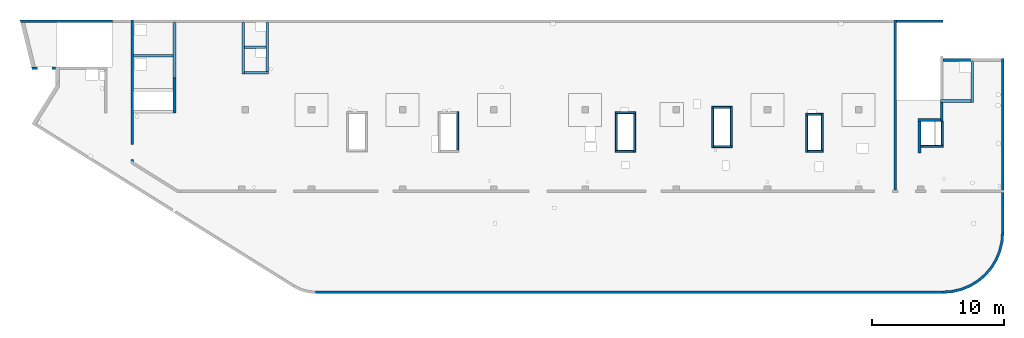
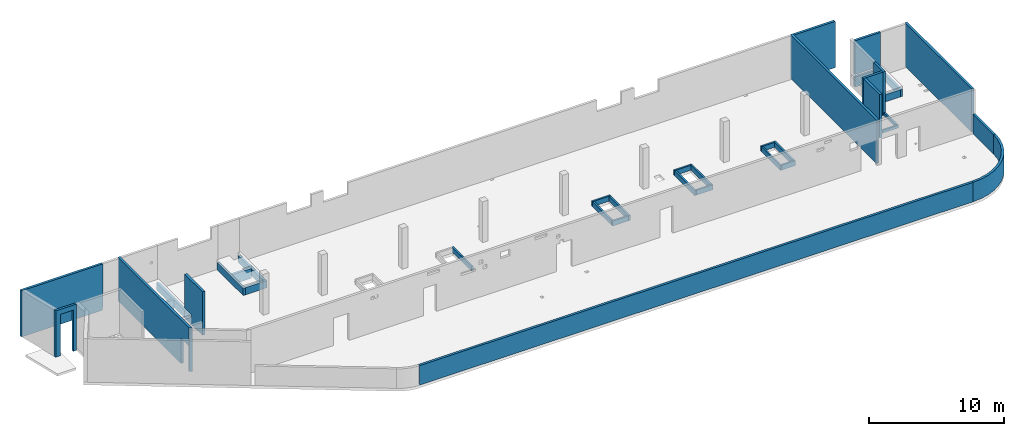
# One storey, part 3 of 6: 37 walls, 3 openings.
"""IFC4 building model written with IfcOpenShell, lengths in millimetres."""

import ifcopenshell
import ifcopenshell.guid

model = None  # the IFC model being written
_history = None  # IfcOwnerHistory: only IFC2X3 demands one
_inside = {}  # id of a spatial element -> (the spatial element, [elements in it])
_under = {}  # id of a project, library or spatial element -> (it, [spatial elements below it])
_declared = {}  # id of a project -> (the project, [libraries it declares])
_typed = {}  # id of a type object -> (the type object, [elements of that type])
_made_of = {}  # id of a material, layer set ... -> (it, [elements and type objects made of it])


def new_model(schema):
    """Start an empty IFC model of exactly this schema.

    Asked for "IFC4X3", IfcOpenShell would pick the latest addendum, in which some entities
    have other attributes; the version numbers below select the first issue.
    IFC2X3 requires an IfcOwnerHistory on every rooted entity: one is made here for all.
    """
    global model, _history
    if schema == "IFC4X3":
        model = ifcopenshell.file(schema_version=(4, 3, 0, 0))
    else:
        model = ifcopenshell.file(schema=schema)
    _inside.clear()
    _under.clear()
    _declared.clear()
    _typed.clear()
    _made_of.clear()
    _history = None
    if model.schema == "IFC2X3":
        org = make("IfcOrganization", Name="unknown")
        user = make(
            "IfcPersonAndOrganization",
            ThePerson=make("IfcPerson", FamilyName="unknown"),
            TheOrganization=org,
        )
        app = make(
            "IfcApplication",
            ApplicationDeveloper=org,
            Version="unknown",
            ApplicationFullName="unknown",
            ApplicationIdentifier="unknown",
        )
        _history = make(
            "IfcOwnerHistory",
            OwningUser=user,
            OwningApplication=app,
            ChangeAction="ADDED",
            CreationDate=0,
        )
    return model


def make(cls, **values):
    """One entity of the class cls with the attributes given. An attribute that is None is left unset."""
    return model.create_entity(
        cls, **{name: value for name, value in values.items() if value is not None}
    )


def entity(cls, *values):
    """Any entity or typed value of the class cls, its attributes in the order of the schema. None: left unset."""
    e = model.create_entity(cls)
    for i, value in enumerate(values):
        if value is not None:
            e[i] = value
    return e


def rooted(cls, **values):
    """An entity with a GlobalId (a new one), such as an element, a storey or a relation."""
    return make(cls, GlobalId=ifcopenshell.guid.new(), OwnerHistory=_history, **values)


def si_unit(unit_type, name, prefix=None):
    """IfcSIUnit, for example si_unit("LENGTHUNIT", "METRE", prefix="MILLI")."""
    return make("IfcSIUnit", UnitType=unit_type, Prefix=prefix, Name=name)


def converted_unit(unit_type, name, factor, base, dimensions=None, offset=None):
    """IfcConversionBasedUnit, such as the inch: factor (a typed value) times the base unit."""
    return make(
        "IfcConversionBasedUnit"
        if offset is None
        else "IfcConversionBasedUnitWithOffset",
        ConversionOffset=offset,
        Dimensions=None
        if dimensions is None
        else entity("IfcDimensionalExponents", *dimensions),
        UnitType=unit_type,
        Name=name,
        ConversionFactor=make(
            "IfcMeasureWithUnit", ValueComponent=factor, UnitComponent=base
        ),
    )


def derived_unit(unit_type, elements):
    """IfcDerivedUnit: a product of units, each with its exponent."""
    return make(
        "IfcDerivedUnit",
        Elements=[
            make("IfcDerivedUnitElement", Unit=unit, Exponent=power)
            for unit, power in elements
        ],
        UnitType=unit_type,
    )


def assignment(units):
    """IfcUnitAssignment: the units of a project."""
    return None if units is None else make("IfcUnitAssignment", Units=units)


def point(xyz):
    """IfcCartesianPoint."""
    return None if xyz is None else make("IfcCartesianPoint", Coordinates=xyz)


def direction(xyz):
    """IfcDirection."""
    return None if xyz is None else make("IfcDirection", DirectionRatios=xyz)


def frame(location, z_axis=None, x_axis=None):
    """IfcAxis2Placement3D, a coordinate frame: its origin and axes. An axis left out is left unset."""
    return make(
        "IfcAxis2Placement3D",
        Location=point(location),
        Axis=direction(z_axis),
        RefDirection=direction(x_axis),
    )


def origin():
    """The frame at (0, 0, 0) with its axes left unset."""
    return frame((0.0, 0.0, 0.0))


def place(relative_to, where):
    """IfcLocalPlacement: puts the frame where relative to a parent placement (None: the world)."""
    return make(
        "IfcLocalPlacement", PlacementRelTo=relative_to, RelativePlacement=where
    )


def context(
    kind, dimensions, precision=None, world=None, true_north=None, identifier=None
):
    """IfcGeometricRepresentationContext, for example the 3D "Model" context."""
    return make(
        "IfcGeometricRepresentationContext",
        ContextIdentifier=identifier,
        ContextType=kind,
        CoordinateSpaceDimension=dimensions,
        Precision=precision,
        WorldCoordinateSystem=world,
        TrueNorth=true_north,
    )


def subcontext(parent, identifier, kind, view, scale=None):
    """IfcGeometricRepresentationSubContext, for example "Body" below "Model"."""
    return make(
        "IfcGeometricRepresentationSubContext",
        ContextIdentifier=identifier,
        ContextType=kind,
        ParentContext=parent,
        TargetScale=scale,
        TargetView=view,
    )


def project(units=None, contexts=None):
    """IfcProject with its units and contexts."""
    return rooted(
        "IfcProject",
        Name="project",
        RepresentationContexts=contexts,
        UnitsInContext=assignment(units),
    )


def spatial(cls, under=None, at=None, **own):
    """A site, building, storey or space (cls), placed at a placement, below another one or the project."""
    s = rooted(cls, ObjectPlacement=at, **own)
    if under is not None:
        _under.setdefault(under.id(), (under, []))[1].append(s)
    return s


def point_list(points):
    """IfcCartesianPointList2D or 3D."""
    cls = (
        "IfcCartesianPointList2D" if len(points[0]) == 2 else "IfcCartesianPointList3D"
    )
    return make(cls, CoordList=points)


def indexed_curve(points, segments=None, self_intersect=None):
    """IfcIndexedPolyCurve: lines and arcs through numbered points (the first is 1)."""
    return make(
        "IfcIndexedPolyCurve",
        Points=point_list(points),
        Segments=segments,
        SelfIntersect=self_intersect,
    )


def outline(outer, holes=None, kind="AREA"):
    """IfcArbitraryClosedProfileDef: a profile drawn as a closed curve; with holes, ...WithVoids."""
    if holes is None:
        return make("IfcArbitraryClosedProfileDef", ProfileType=kind, OuterCurve=outer)
    return make(
        "IfcArbitraryProfileDefWithVoids",
        ProfileType=kind,
        OuterCurve=outer,
        InnerCurves=holes,
    )


def extrude(swept, where, along, depth):
    """IfcExtrudedAreaSolid: the profile swept, set in the frame where, extruded along a direction by depth."""
    return make(
        "IfcExtrudedAreaSolid",
        SweptArea=swept,
        Position=where,
        ExtrudedDirection=direction(along),
        Depth=depth,
    )


def polygons(points, faces, closed=None, point_numbers=None):
    """IfcPolygonalFaceSet: a face is its outer loop, then its inner loops; points numbered from 1."""
    made = []
    for loops in faces:
        if len(loops) == 1:
            made.append(make("IfcIndexedPolygonalFace", CoordIndex=loops[0]))
        else:
            made.append(
                make(
                    "IfcIndexedPolygonalFaceWithVoids",
                    CoordIndex=loops[0],
                    InnerCoordIndices=loops[1:],
                )
            )
    return make(
        "IfcPolygonalFaceSet",
        Coordinates=point_list(points),
        Closed=closed,
        Faces=made,
        PnIndex=point_numbers,
    )


def shape(context_of_items, identifier, shape_type, items):
    """IfcShapeRepresentation: the items that make up one representation, for example the "Body"."""
    return make(
        "IfcShapeRepresentation",
        ContextOfItems=context_of_items,
        RepresentationIdentifier=identifier,
        RepresentationType=shape_type,
        Items=items,
    )


def material(Name=None, Category=None):
    """IfcMaterial."""
    return make("IfcMaterial", Name=Name, Category=Category)


def made_of(thing, what):
    """Note that an element or type object is made of a material, layer set ...; save() writes the relation."""
    if what is not None:
        _made_of.setdefault(what.id(), (what, []))[1].append(thing)
    return thing


def type_object(cls, material=None, **own):
    """A type object (cls), such as IfcWallType, which elements share."""
    return made_of(rooted(cls, **own), material)


def element(
    cls,
    number,
    at=None,
    inside=None,
    cuts=None,
    type_object=None,
    material=None,
    context=None,
    identifier="Body",
    shape_type=None,
    held_by="IfcProductDefinitionShape",
    body=None,
    shapes=None,
    **own,
):
    """One element of the class cls, such as IfcWall. Its Tag is "e" and its number.

    at: its placement. inside: the storey or other place that contains it. cuts: it is an
    opening in that element (IfcRelVoidsElement). A single representation is given by context,
    identifier, shape_type and body (its items); several are given by shapes. held_by: the class
    of the entity that holds the representations. save() writes the other relations.
    """
    e = rooted(cls, Tag="e%d" % number, ObjectPlacement=at, **own)
    if body is not None:
        shapes = [shape(context, identifier, shape_type, body)]
    if shapes is not None:
        e.Representation = make(held_by, Representations=shapes)
    if inside is not None:
        _inside.setdefault(inside.id(), (inside, []))[1].append(e)
    if cuts is not None:
        rooted(
            "IfcRelVoidsElement", RelatingBuildingElement=cuts, RelatedOpeningElement=e
        )
    if type_object is not None:
        _typed.setdefault(type_object.id(), (type_object, []))[1].append(e)
    return made_of(e, material)


def aggregate(whole, parts):
    """IfcRelAggregates: a whole, such as a stair, and the parts it consists of."""
    return rooted("IfcRelAggregates", RelatingObject=whole, RelatedObjects=parts)


def save(model, path):
    """Write the relations noted so far, then the file.

    IfcRelAggregates (storeys below a building ...), IfcRelContainedInSpatialStructure (elements
    in a storey), IfcRelDefinesByType, IfcRelAssociatesMaterial and IfcRelDeclares: one each for
    every whole, place, type object, material and project.
    """
    for whole, parts in _under.values():
        aggregate(whole, parts)
    for where, things in _inside.values():
        rooted(
            "IfcRelContainedInSpatialStructure",
            RelatedElements=things,
            RelatingStructure=where,
        )
    for kind, things in _typed.values():
        rooted("IfcRelDefinesByType", RelatedObjects=things, RelatingType=kind)
    for what, things in _made_of.values():
        rooted("IfcRelAssociatesMaterial", RelatedObjects=things, RelatingMaterial=what)
    for by, libraries in _declared.values():
        rooted("IfcRelDeclares", RelatingContext=by, RelatedDefinitions=libraries)
    model.write(path)


model = new_model("IFC4")

# Units and contexts
model_context = context("Model", 3, precision=0.01, world=origin(), true_north=direction((6.12303176911189e-17, 1.0)))
plan_context = context("Plan", 3, precision=0.01, world=origin(), true_north=direction((6.12303176911189e-17, 1.0)))
body_context = subcontext(model_context, "Body", "Model", "MODEL_VIEW")
ifc_project = project(units=[si_unit("LENGTHUNIT", "METRE", prefix="MILLI"), si_unit("AREAUNIT", "SQUARE_METRE"), si_unit("VOLUMEUNIT", "CUBIC_METRE"), converted_unit("PLANEANGLEUNIT", "DEGREE", entity("IfcRatioMeasure", 0.0174532925199433), si_unit("PLANEANGLEUNIT", "RADIAN"), dimensions=[0, 0, 0, 0, 0, 0, 0]), si_unit("MASSUNIT", "GRAM", prefix="KILO"), derived_unit("MASSDENSITYUNIT", [(si_unit("MASSUNIT", "GRAM", prefix="KILO"), 1), (si_unit("LENGTHUNIT", "METRE"), -3)]), derived_unit("MOMENTOFINERTIAUNIT", [(si_unit("LENGTHUNIT", "METRE"), 4)]), si_unit("TIMEUNIT", "SECOND"), si_unit("FREQUENCYUNIT", "HERTZ"), si_unit("THERMODYNAMICTEMPERATUREUNIT", "DEGREE_CELSIUS"), derived_unit("THERMALTRANSMITTANCEUNIT", [(si_unit("MASSUNIT", "GRAM", prefix="KILO"), 1), (si_unit("THERMODYNAMICTEMPERATUREUNIT", "KELVIN"), -1), (si_unit("TIMEUNIT", "SECOND"), -3)]), derived_unit("VOLUMETRICFLOWRATEUNIT", [(si_unit("LENGTHUNIT", "METRE"), 3), (si_unit("TIMEUNIT", "SECOND"), -1)]), derived_unit("MASSFLOWRATEUNIT", [(si_unit("MASSUNIT", "GRAM", prefix="KILO"), 1), (si_unit("TIMEUNIT", "SECOND"), -1)]), derived_unit("ROTATIONALFREQUENCYUNIT", [(si_unit("TIMEUNIT", "SECOND"), -1)]), si_unit("ELECTRICCURRENTUNIT", "AMPERE"), si_unit("ELECTRICVOLTAGEUNIT", "VOLT"), si_unit("POWERUNIT", "WATT"), si_unit("FORCEUNIT", "NEWTON", prefix="KILO"), si_unit("ILLUMINANCEUNIT", "LUX"), si_unit("LUMINOUSFLUXUNIT", "LUMEN"), si_unit("LUMINOUSINTENSITYUNIT", "CANDELA"), derived_unit("USERDEFINED", [(si_unit("MASSUNIT", "GRAM", prefix="KILO"), -1), (si_unit("LENGTHUNIT", "METRE"), -2), (si_unit("TIMEUNIT", "SECOND"), 3), (si_unit("LUMINOUSFLUXUNIT", "LUMEN"), 1)]), derived_unit("LINEARVELOCITYUNIT", [(si_unit("LENGTHUNIT", "METRE"), 1), (si_unit("TIMEUNIT", "SECOND"), -1)]), si_unit("PRESSUREUNIT", "PASCAL"), derived_unit("USERDEFINED", [(si_unit("LENGTHUNIT", "METRE"), -2), (si_unit("MASSUNIT", "GRAM", prefix="KILO"), 1), (si_unit("TIMEUNIT", "SECOND"), -2)]), derived_unit("LINEARFORCEUNIT", [(si_unit("MASSUNIT", "GRAM", prefix="KILO"), 1), (si_unit("LENGTHUNIT", "METRE"), 1), (si_unit("TIMEUNIT", "SECOND"), -2), (si_unit("LENGTHUNIT", "METRE"), -1)]), derived_unit("PLANARFORCEUNIT", [(si_unit("MASSUNIT", "GRAM", prefix="KILO"), 1), (si_unit("LENGTHUNIT", "METRE"), 1), (si_unit("TIMEUNIT", "SECOND"), -2), (si_unit("LENGTHUNIT", "METRE"), -2)])], contexts=[model_context, plan_context])

# Site, building, storey
site_placement = place(None, origin())
site = spatial("IfcSite", under=ifc_project, at=site_placement, CompositionType="ELEMENT")
building_placement = place(site_placement, origin())
building = spatial("IfcBuilding", under=site, at=building_placement, CompositionType="ELEMENT")
storey_placement = place(building_placement, frame((0.0, 0.0, 28200.0)))
storey = spatial("IfcBuildingStorey", under=building, at=storey_placement, CompositionType="ELEMENT", Elevation=28200.0)

# Wall, opening
ifc_material = material()
wall_type_1 = type_object("IfcWallType", PredefinedType="STANDARD")
wall_1_placement = place(storey_placement, frame((1805.00026855469, 16859.9992263559, -400.0), z_axis=(0.0, 0.0, 1.0), x_axis=(-1.0, 0.0, 0.0)))
wall_1 = element("IfcWall", 1, at=wall_1_placement, inside=storey, type_object=wall_type_1, material=ifc_material, PredefinedType="NOTDEFINED", context=body_context, shape_type="Tessellation", body=[
    polygons([(1834.46650967482, -100.000000000001, 4200.0), (1525.68223251125, -100.000000000001, 4200.0), (2.33197173806285e-13, -100.000000000001, 4200.0), (2.33197173806285e-13, -100.000000000001, 249.999999999999), (2.33197173806285e-13, -100.000000000001, 0.0), (275.0, -100.000000000001, 0.0), (275.0, -100.000000000322, 3750.0), (1375.0, -100.000000000324, 3750.0), (1375.0, -100.000000000003, 0.0), (1525.68223251125, -100.000000000001, 0.0), (1834.46650967482, -100.000000000001, 0.0), (-6.38934712472434e-14, 100.000000000001, 4200.0), (1785.71439371649, 99.9999999999989, 4200.0), (1785.71439371649, 99.9999999999989, 0.0), (1375.0, 99.9999999999968, 0.0), (1375.0, 99.9999999999968, 3750.00000000001), (275.0, 100.000000000001, 3750.00000000001), (275.0, 100.000000000001, 0.0), (-6.38934712472434e-14, 100.000000000001, 0.0)], [[[1, 2, 3, 4, 5, 6, 7, 8, 9, 10, 11]], [[12, 13, 14, 15, 16, 17, 18, 19]], [[5, 19, 18, 6]], [[3, 2, 1, 13, 12]], [[5, 4, 3, 12, 19]], [[1, 11, 14, 13]], [[16, 8, 7, 17]], [[8, 16, 15, 9]], [[17, 7, 6, 18]], [[14, 11, 10, 9, 15]]], closed=True),
])
opening_1_placement = place(wall_1_placement, frame((1805.00026855469, 16859.9992263559, 400.0), z_axis=(0.0, 0.0, 1.0), x_axis=(-1.0, 0.0, 0.0)))
element("IfcOpeningElement", 2, at=opening_1_placement, cuts=wall_1, PredefinedType="OPENING", context=body_context, shape_type="SweptSolid", body=[
    extrude(outline(indexed_curve([(-550.0, -3149.99999999999), (550.0, -3149.99999999999), (550.0, 3149.99999999999), (-550.0, 3149.99999999999), (-550.0, -3149.99999999999)], self_intersect=False)), frame((980.000268554694, 16959.9992263569, 200.0), z_axis=(0.0, -1.0, 0.0), x_axis=(-1.0, 0.0, 0.0)), (0.0, 0.0, 1.0), 200.000000000962),
])

# Wall
wall_2_placement = place(storey_placement, frame((-892.378849434978, 20399.9998657227, -400.0)))
element("IfcWall", 3, at=wall_2_placement, inside=storey, type_object=wall_type_1, material=ifc_material, PredefinedType="NOTDEFINED", context=body_context, shape_type="Tessellation", body=[
    polygons([(6992.37911798968, -99.9999999999989, 4200.0), (357.536393121909, -99.9999999999989, 4200.0), (48.7521159583308, -100.000000000003, 4200.0), (48.7521159583318, -100.000000000003, 0.0), (357.536393121908, -99.9999999999989, 0.0), (6962.37911798968, -99.9999999999989, 0.0), (6962.37911798968, -99.9999999999989, 249.999999999999), (6992.37911798968, -99.9999999999989, 249.999999999999), (8.98797485695457e-13, 99.9999999999989, 4200.0), (0.379117989658529, 99.9999999999989, 4200.0), (6992.37911798968, 100.000000000003, 4200.0), (6992.37911798968, 100.000000000003, 249.999999999999), (6962.37911798968, 100.000000000008, 249.999999999999), (6962.37911798968, 100.000000000003, 0.0), (308.784277163562, 100.000000000003, 0.0), (-4.87112524406362e-14, 99.9999999999989, 0.0)], [[[1, 2, 3, 4, 5, 6, 7, 8]], [[9, 10, 11, 12, 13, 14, 15, 16]], [[4, 16, 15, 14, 6, 5]], [[11, 1, 8, 12]], [[3, 2, 1, 11, 10, 9]], [[4, 3, 9, 16]], [[7, 13, 12, 8]], [[13, 7, 6, 14]]], closed=True),
])

# Wall, opening
wall_3_placement = place(storey_placement, frame((7600.0002685547, 20499.9998657227, -150.0), z_axis=(0.0, 0.0, 1.0), x_axis=(0.0, -1.0, 0.0)))
wall_3 = element("IfcWall", 4, at=wall_3_placement, inside=storey, type_object=wall_type_1, material=ifc_material, PredefinedType="NOTDEFINED", context=body_context, shape_type="Tessellation", body=[
    polygons([(10624.9984109254, -99.9999999999999, 3950.0), (1979.99999999983, -100.0, 3950.0), (1019.99999999983, -99.9999999999994, 3950.0), (200.000000000037, -99.9999999999996, 3950.0), (0.0, -100.000000000001, 3950.0), (0.0, -100.000000000001, 0.0), (200.000000000037, -99.9999999999996, 0.0), (9420.00063936629, -99.9999999999996, 0.0), (9420.00063936629, -99.9999999999996, 2279.99999999804), (10550.0006393663, -99.999999999999, 2279.99999999804), (10550.0006393663, -100.0, 0.0), (10624.9984109254, -99.9999999999999, 0.0), (0.0, 100.0, 3950.0), (199.999999999998, 100.0, 3950.0), (10749.9698423134, 100.0, 3950.0), (10749.9698423134, 100.0, 0.0), (10550.0006393663, 100.0, 0.0), (10550.0006393663, 100.0, 2279.99999999804), (9420.0006393663, 100.0, 2279.99999999804), (9420.00063936629, 100.0, 0.0), (7050.00063936683, 100.0, 0.0), (6850.00063936683, 100.000000000001, 0.0), (6800.00000000003, 100.000000000001, 0.0), (5400.00000000003, 100.000000000001, 0.0), (5200.00000000003, 100.0, 0.0), (0.0, 100.0, 0.0)], [[[1, 2, 3, 4, 5, 6, 7, 8, 9, 10, 11, 12]], [[13, 14, 15, 16, 17, 18, 19, 20, 21, 22, 23, 24, 25, 26]], [[6, 26, 25, 24, 23, 22, 21, 20, 8, 7]], [[5, 4, 3, 2, 1, 15, 14, 13]], [[1, 12, 16, 15]], [[6, 5, 13, 26]], [[9, 19, 18, 10]], [[10, 18, 17, 11]], [[19, 9, 8, 20]], [[16, 12, 11, 17]]], closed=True),
])
opening_2_placement = place(wall_3_placement, frame((20499.9998657227, -7600.0002685547, 150.0), z_axis=(0.0, 0.0, 1.0), x_axis=(0.0, 1.0, 0.0)))
element("IfcOpeningElement", 5, at=opening_2_placement, cuts=wall_3, PredefinedType="OPENING", context=body_context, shape_type="SweptSolid", body=[
    extrude(outline(indexed_curve([(-564.999999999999, -1139.99999999902), (564.999999999999, -1139.99999999902), (564.999999999999, 1139.99999999902), (-564.999999999999, 1139.99999999902), (-564.999999999999, -1139.99999999902)], self_intersect=False)), frame((7400.00026855274, 10514.9992263564, 990.0), z_axis=(1.0, 0.0, 0.0), x_axis=(0.0, -1.0, 0.0)), (0.0, 0.0, 1.0), 400.000000001943),
])

# Walls
wall_4_placement = place(storey_placement, frame((21464.844771801, -99.9999557732789, -150.0)))
element("IfcWall", 6, at=wall_4_placement, inside=storey, type_object=wall_type_1, material=ifc_material, PredefinedType="NOTDEFINED", context=body_context, shape_type="SweptSolid", body=[
    extrude(outline(indexed_curve([(47505.1554967537, 100.0), (-3.23209822019764e-13, 100.0), (3.23209822019764e-13, -100.0), (47505.1554967537, -100.0), (47505.1554967537, 100.0)], self_intersect=False)), origin(), (0.0, 0.0, 1.0), 1770.0),
])
wall_5_placement = place(storey_placement, frame((68970.0002685545, -99.9999557734324, -150.0)))
element("IfcWall", 7, at=wall_5_placement, inside=storey, type_object=wall_type_1, material=ifc_material, PredefinedType="NOTDEFINED", context=body_context, shape_type="SweptSolid", body=[
    extrude(outline(indexed_curve([(4399.99918212903, 4499.99918212888), (4345.82789081698, 3811.68766389508), (4184.64789385715, 3140.32465961517), (3920.42797770043, 2502.44135458057), (3559.67411357824, 1913.74455277455), (3111.26925889869, 1388.72992323025), (2586.25462935438, 940.325068550714), (1997.55782754836, 579.571204428536), (1359.67452251375, 315.35128827184), (688.311518233829, 154.171291312031), (3.46517481375486e-11, 100.0), (0.0, -100.0), (719.598411241839, -43.3663768070019), (1421.4779213887, 125.139985012799), (2088.35592749624, 401.369899590848), (2703.81167981285, 778.521669675704), (3252.69061513598, 1247.30856699292), (3721.47751245321, 1796.18750231603), (4098.6292825381, 2411.64325463263), (4374.85919711618, 3078.52126074015), (4543.365558936, 3780.40077088701), (4599.99918212902, 4499.99918212885), (4399.99918212903, 4499.99918212888)], self_intersect=False)), origin(), (0.0, 0.0, 1.0), 1770.0),
])
wall_6_placement = place(storey_placement, frame((73469.9994506836, 4399.99922635542, -150.0), z_axis=(0.0, 0.0, 1.0), x_axis=(0.0, 1.0, 0.0)))
element("IfcWall", 8, at=wall_6_placement, inside=storey, type_object=wall_type_1, material=ifc_material, PredefinedType="NOTDEFINED", context=body_context, shape_type="SweptSolid", body=[
    extrude(outline(indexed_curve([(3050.00000000025, 100.000000000001), (-2.03485596397248e-13, 100.000000000003), (2.03485596397248e-13, -100.000000000003), (3050.00000000025, -100.000000000006), (3050.00000000025, 100.000000000001)], self_intersect=False)), origin(), (0.0, 0.0, 1.0), 1770.0),
])
wall_7_placement = place(storey_placement, frame((73469.9994506836, 7649.99922635566, -150.0), z_axis=(0.0, 0.0, 1.0), x_axis=(0.0, 1.0, 0.0)))
element("IfcWall", 9, at=wall_7_placement, inside=storey, type_object=wall_type_1, material=ifc_material, PredefinedType="NOTDEFINED", context=body_context, shape_type="SweptSolid", body=[
    extrude(outline(indexed_curve([(9919.99999999979, 100.000000000003), (-1.74655988596524e-13, 100.000000000003), (1.74655988596524e-13, -100.000000000003), (9919.99999999979, -100.000000000003), (9919.99999999979, 100.000000000003)], self_intersect=False)), origin(), (0.0, 0.0, 1.0), 3950.0),
])
wall_8_placement = place(storey_placement, frame((71169.9994506836, 17369.9992263555, -150.0), z_axis=(0.0, 0.0, 1.0), x_axis=(0.0, -1.0, 0.0)))
element("IfcWall", 10, at=wall_8_placement, inside=storey, type_object=wall_type_1, material=ifc_material, PredefinedType="NOTDEFINED", context=body_context, shape_type="SweptSolid", body=[
    extrude(outline(indexed_curve([(3100.0, 100.000000000003), (-2.79449581754433e-13, 100.000000000003), (2.79449581754433e-13, -100.000000000003), (3100.0, -100.000000000003), (3100.0, 100.000000000003)], self_intersect=False)), origin(), (0.0, 0.0, 1.0), 650.0),
])
wall_9_placement = place(storey_placement, frame((71069.9994506836, 14369.9992263555, -150.0), z_axis=(0.0, 0.0, 1.0), x_axis=(-1.0, 0.0, 0.0)))
element("IfcWall", 11, at=wall_9_placement, inside=storey, type_object=wall_type_1, material=ifc_material, PredefinedType="NOTDEFINED", context=body_context, shape_type="SweptSolid", body=[
    extrude(outline(indexed_curve([(2299.99918212887, 99.9999999999989), (-2.82487177659624e-13, 99.9999999999989), (2.82487177659624e-13, -99.9999999999989), (2299.99918212887, -99.9999999999989), (2299.99918212887, 99.9999999999989)], self_intersect=False)), origin(), (0.0, 0.0, 1.0), 650.0),
])
wall_10_placement = place(storey_placement, frame((68870.0002685547, 14369.9992263555, -150.0), z_axis=(0.0, 0.0, 1.0), x_axis=(0.0, -1.0, 0.0)))
element("IfcWall", 12, at=wall_10_placement, inside=storey, type_object=wall_type_1, material=ifc_material, PredefinedType="NOTDEFINED", context=body_context, shape_type="SweptSolid", body=[
    extrude(outline(indexed_curve([(1539.99999999999, -99.9999999999946), (1539.99999999999, -49.9999999999713), (1539.99999999999, 100.000000000003), (99.9999999999989, 100.000000000003), (99.9999999999989, -99.9999999999946), (1339.99999999999, -99.9999999999946), (1539.99999999999, -99.9999999999946)], self_intersect=False)), origin(), (0.0, 0.0, 1.0), 3950.0),
])
wall_11_placement = place(storey_placement, frame((68770.0002685547, 12929.9992263555, -150.0), z_axis=(0.0, 0.0, 1.0), x_axis=(-1.0, 0.0, 0.0)))
element("IfcWall", 13, at=wall_11_placement, inside=storey, type_object=wall_type_1, material=ifc_material, PredefinedType="NOTDEFINED", context=body_context, shape_type="SweptSolid", body=[
    extrude(outline(indexed_curve([(1689.99999999997, 99.9999999999989), (-3.84449868389964e-13, 99.9999999999989), (3.84449868389964e-13, -99.9999999999989), (1689.99999999997, -99.9999999999989), (1689.99999999997, 99.9999999999989)], self_intersect=False)), origin(), (0.0, 0.0, 1.0), 3950.0),
])
wall_12_placement = place(storey_placement, frame((67180.0002685547, 12829.9992263555, -150.0), z_axis=(0.0, 0.0, 1.0), x_axis=(0.0, -1.0, 0.0)))
element("IfcWall", 14, at=wall_12_placement, inside=storey, type_object=wall_type_1, material=ifc_material, PredefinedType="NOTDEFINED", context=body_context, shape_type="SweptSolid", body=[
    extrude(outline(indexed_curve([(2404.99999999995, 100.000000000003), (0.0, 100.000000000003), (0.0, -100.000000000003), (2404.99999999995, -100.000000000003), (2404.99999999995, 100.000000000003)], self_intersect=False)), origin(), (0.0, 0.0, 1.0), 3950.0),
])
wall_13_placement = place(storey_placement, frame((65330.0002685547, 7649.99922635569, -150.0), z_axis=(0.0, 0.0, 1.0), x_axis=(0.0, 1.0, 0.0)))
element("IfcWall", 15, at=wall_13_placement, inside=storey, type_object=wall_type_1, material=ifc_material, PredefinedType="NOTDEFINED", context=body_context, shape_type="SweptSolid", body=[
    extrude(outline(indexed_curve([(12850.000639367, 100.0), (-1.79078789910118e-13, 100.000000000003), (1.79078789910118e-13, -100.000000000003), (12850.000639367, -100.000000000006), (12850.000639367, 100.0)], self_intersect=False)), origin(), (0.0, 0.0, 1.0), 3950.0),
])

# Wall, opening
wall_14_placement = place(storey_placement, frame((71169.9994506836, 17469.9992263555, -400.0), z_axis=(0.0, 0.0, 1.0), x_axis=(-1.0, 0.0, 0.0)))
wall_14 = element("IfcWall", 16, at=wall_14_placement, inside=storey, type_object=wall_type_1, material=ifc_material, PredefinedType="NOTDEFINED", context=body_context, shape_type="SweptSolid", body=[
    extrude(outline(indexed_curve([(2199.99918212889, 99.9999999999992), (-3.09390728867033e-13, 99.9999999999989), (3.09390728867033e-13, -99.9999999999989), (2199.99918212889, -99.9999999999986), (2199.99918212889, 99.9999999999992)], self_intersect=False)), origin(), (0.0, 0.0, 1.0), 4200.0),
])
opening_3_placement = place(storey_placement, frame((71169.9994506836, 17469.9992263555, -400.0), z_axis=(0.0, 0.0, 1.0), x_axis=(-1.0, 0.0, 0.0)))
element("IfcOpeningElement", 17, at=opening_3_placement, cuts=wall_14, PredefinedType="OPENING", context=body_context, shape_type="SweptSolid", body=[
    extrude(outline(indexed_curve([(-1009.99967285155, -120.0), (1089.99950927734, -120.0), (1089.99950927734, 80.0000000000003), (-159.999672851545, 80.0000000000008), (-1009.99967285155, 80.0000000000003), (-1009.99967285155, -120.0)], self_intersect=False)), frame((1109.99967285155, 20.0, 900.0)), (0.0, 0.0, 1.0), 249.999999999999),
])

# Walls
wall_15_placement = place(storey_placement, frame((65430.0002685547, 20399.9998657227, -400.0)))
element("IfcWall", 18, at=wall_15_placement, inside=storey, type_object=wall_type_1, material=ifc_material, PredefinedType="NOTDEFINED", context=body_context, shape_type="SweptSolid", body=[
    extrude(outline(indexed_curve([(3539.99999999996, 99.9999999999986), (-3.56989163504965e-13, 99.9999999999989), (3.56989163504965e-13, -99.9999999999989), (3539.99999999996, -99.9999999999993), (3539.99999999996, 99.9999999999986)], self_intersect=False)), origin(), (0.0, 0.0, 1.0), 4200.0),
])
wall_16_placement = place(storey_placement, frame((10800.0002685547, 13449.9992263559, -150.0), z_axis=(0.0, 0.0, 1.0), x_axis=(0.0, 1.0, 0.0)))
element("IfcWall", 19, at=wall_16_placement, inside=storey, type_object=wall_type_1, material=ifc_material, PredefinedType="NOTDEFINED", context=body_context, shape_type="Tessellation", body=[
    polygons([(-2.16573425859679e-12, -100.000000000002, 0.0), (2650.0, -100.000000000002, 0.0), (2650.0, -100.000000000002, 650.000000000004), (1650.0006393668, -100.000000000004, 650.000000000004), (1650.0006393668, -100.000000000004, 899.999999999999), (2650.0, -100.000000000002, 899.999999999999), (2650.0, -100.000000000002, 3950.0), (-2.16573425859679e-12, -100.000000000002, 3950.0), (2650.0, 99.9999999999981, 0.0), (1850.00063936679, 99.999999999997, 0.0), (1650.00063936679, 99.9999999999979, 0.0), (250.000639366811, 99.9999999999971, 0.0), (200.0, 99.9999999999973, 0.0), (0.0, 99.9999999999981, 0.0), (0.0, 99.9999999999981, 1200.0), (0.0, 99.9999999999981, 3950.0), (2650.0, 99.9999999999981, 3950.0), (2650.0, 99.9999999999981, 899.999999999999), (1650.0006393668, 99.9999999999979, 899.999999999999), (1650.0006393668, 99.9999999999979, 650.000000000004), (1850.00063936679, 99.999999999997, 650.0), (2650.0, 99.9999999999981, 650.000000000004)], [[[1, 2, 3, 4, 5, 6, 7, 8]], [[9, 10, 11, 12, 13, 14, 15, 16, 17, 18, 19, 20, 21, 22]], [[2, 1, 14, 13, 12, 11, 10, 9]], [[2, 9, 22, 3]], [[8, 7, 17, 16]], [[20, 4, 3, 22, 21]], [[5, 19, 18, 6]], [[4, 20, 19, 5]], [[1, 8, 16, 15, 14]], [[17, 7, 6, 18]]], closed=True),
])
wall_17_placement = place(storey_placement, frame((10800.0002685547, 16099.9992263559, -150.0), z_axis=(0.0, 0.0, 1.0), x_axis=(0.0, 1.0, 0.0)))
element("IfcWall", 20, at=wall_17_placement, inside=storey, type_object=wall_type_1, material=ifc_material, PredefinedType="NOTDEFINED", context=body_context, shape_type="SweptSolid", body=[
    extrude(outline(indexed_curve([(4200.00063936683, 99.9999999999989), (-1.5469528063619e-13, 99.9999999999989), (1.5469528063619e-13, -99.9999999999989), (4200.00063936683, -99.9999999999989), (4200.00063936683, 99.9999999999989)], self_intersect=False)), origin(), (0.0, 0.0, 1.0), 650.0),
])
wall_18_placement = place(storey_placement, frame((16000.0002685547, 16399.9992263558, -150.0), z_axis=(0.0, 0.0, 1.0), x_axis=(0.0, 1.0, 0.0)))
element("IfcWall", 21, at=wall_18_placement, inside=storey, type_object=wall_type_1, material=ifc_material, PredefinedType="NOTDEFINED", context=body_context, shape_type="SweptSolid", body=[
    extrude(outline(indexed_curve([(3900.00063936682, 99.9999999999989), (-1.66594915657376e-13, 99.9999999999989), (1.66594915657376e-13, -99.9999999999989), (3900.00063936682, -99.9999999999989), (3900.00063936682, 99.9999999999989)], self_intersect=False)), origin(), (0.0, 0.0, 1.0), 650.0),
])
wall_19_placement = place(storey_placement, frame((16100.0002685547, 16499.9992263558, -150.0)))
element("IfcWall", 22, at=wall_19_placement, inside=storey, type_object=wall_type_1, material=ifc_material, PredefinedType="NOTDEFINED", context=body_context, shape_type="SweptSolid", body=[
    extrude(outline(indexed_curve([(1824.99999999998, 99.9999999999989), (-3.56011111002211e-13, 99.9999999999989), (3.56011111002211e-13, -99.9999999999989), (1824.99999999998, -99.9999999999989), (1824.99999999998, 99.9999999999989)], self_intersect=False)), origin(), (0.0, 0.0, 1.0), 650.0),
])
wall_20_placement = place(storey_placement, frame((17825.0002685547, 16599.9992263558, -150.0), z_axis=(0.0, 0.0, 1.0), x_axis=(0.0, 1.0, 0.0)))
element("IfcWall", 23, at=wall_20_placement, inside=storey, type_object=wall_type_1, material=ifc_material, PredefinedType="NOTDEFINED", context=body_context, shape_type="SweptSolid", body=[
    extrude(outline(indexed_curve([(3700.00063936685, 99.9999999999986), (-1.66594915657375e-13, 99.9999999999989), (1.66594915657375e-13, -99.9999999999989), (3700.00063936685, -99.9999999999993), (3700.00063936685, 99.9999999999986)], self_intersect=False)), origin(), (0.0, 0.0, 1.0), 650.0),
])
wall_21_placement = place(storey_placement, frame((16100.0002685547, 18449.9998657227, -400.0)))
element("IfcWall", 24, at=wall_21_placement, inside=storey, type_object=wall_type_1, material=ifc_material, PredefinedType="NOTDEFINED", context=body_context, shape_type="SweptSolid", body=[
    extrude(outline(indexed_curve([(1624.99999999999, 99.9999999999989), (-2.66551908750372e-13, 99.9999999999989), (2.66551908750372e-13, -99.9999999999989), (1624.99999999999, -99.9999999999989), (1624.99999999999, 99.9999999999989)], self_intersect=False)), origin(), (0.0, 0.0, 1.0), 900.000000000003),
])
wall_22_placement = place(storey_placement, frame((10700.0002685547, 17799.9998657227, -400.0), z_axis=(0.0, 0.0, 1.0), x_axis=(-1.0, 0.0, 0.0)))
element("IfcWall", 25, at=wall_22_placement, inside=storey, type_object=wall_type_1, material=ifc_material, PredefinedType="NOTDEFINED", context=body_context, shape_type="SweptSolid", body=[
    extrude(outline(indexed_curve([(2999.99999999999, 99.9999999999989), (-2.88764567812902e-13, 99.9999999999989), (2.88764567812902e-13, -99.9999999999989), (2999.99999999999, -99.9999999999989), (2999.99999999999, 99.9999999999989)], self_intersect=False)), origin(), (0.0, 0.0, 1.0), 900.000000000003),
])
wall_type_2 = type_object("IfcWallType", PredefinedType="STANDARD")
wall_23_placement = place(storey_placement, frame((32245.0002685547, 13549.9992263562, -150.0), z_axis=(0.0, 0.0, 1.0), x_axis=(0.0, -1.0, 0.0)))
element("IfcWall", 26, at=wall_23_placement, inside=storey, type_object=wall_type_2, material=ifc_material, PredefinedType="NOTDEFINED", context=body_context, shape_type="SweptSolid", body=[
    extrude(outline(indexed_curve([(2925.0, 75.0000000000003), (0.0, 75.0000000000003), (0.0, -75.0000000000003), (2925.0, -75.0000000000003), (2925.0, 75.0000000000003)], self_intersect=False)), origin(), (0.0, 0.0, 1.0), 450.000000000002),
])
wall_24_placement = place(storey_placement, frame((44160.0002685547, 13474.9992263562, -150.0)))
element("IfcWall", 27, at=wall_24_placement, inside=storey, type_object=wall_type_2, material=ifc_material, PredefinedType="NOTDEFINED", context=body_context, shape_type="SweptSolid", body=[
    extrude(outline(indexed_curve([(1559.99999999999, 75.0000000000013), (-2.57825506975811e-13, 75.0000000000003), (2.57825506975811e-13, -75.0000000000003), (1559.99999999999, -74.9999999999992), (1559.99999999999, 75.0000000000013)], self_intersect=False)), origin(), (0.0, 0.0, 1.0), 450.000000000002),
])
wall_25_placement = place(storey_placement, frame((45645.0002685547, 13399.9992263562, -150.0), z_axis=(0.0, 0.0, 1.0), x_axis=(0.0, -1.0, 0.0)))
element("IfcWall", 28, at=wall_25_placement, inside=storey, type_object=wall_type_2, material=ifc_material, PredefinedType="NOTDEFINED", context=body_context, shape_type="SweptSolid", body=[
    extrude(outline(indexed_curve([(2924.99999999998, 75.0000000000007), (-2.34133433361817e-13, 75.0000000000003), (2.34133433361817e-13, -75.0000000000003), (2924.99999999998, -74.9999999999998), (2924.99999999998, 75.0000000000007)], self_intersect=False)), origin(), (0.0, 0.0, 1.0), 450.000000000002),
])
wall_26_placement = place(storey_placement, frame((45570.0002685547, 10549.9992263562, -150.0), z_axis=(0.0, 0.0, 1.0), x_axis=(-1.0, 0.0, 0.0)))
element("IfcWall", 29, at=wall_26_placement, inside=storey, type_object=wall_type_2, material=ifc_material, PredefinedType="NOTDEFINED", context=body_context, shape_type="SweptSolid", body=[
    extrude(outline(indexed_curve([(1409.99999999998, 75.0000000000008), (-2.57825506975812e-13, 75.0000000000003), (2.57825506975812e-13, -75.0000000000003), (1409.99999999998, -74.9999999999998), (1409.99999999998, 75.0000000000008)], self_intersect=False)), origin(), (0.0, 0.0, 1.0), 450.000000000002),
])
wall_27_placement = place(storey_placement, frame((44235.0002685547, 10624.9992263562, -150.0), z_axis=(0.0, 0.0, 1.0), x_axis=(0.0, 1.0, 0.0)))
element("IfcWall", 30, at=wall_27_placement, inside=storey, type_object=wall_type_2, material=ifc_material, PredefinedType="NOTDEFINED", context=body_context, shape_type="SweptSolid", body=[
    extrude(outline(indexed_curve([(2774.99999999998, 75.0000000000003), (0.0, 75.0000000000003), (0.0, -75.0000000000003), (2774.99999999998, -75.0000000000003), (2774.99999999998, 75.0000000000003)], self_intersect=False)), origin(), (0.0, 0.0, 1.0), 450.000000000002),
])
wall_28_placement = place(storey_placement, frame((51440.0002685547, 13909.9992263556, -150.0)))
element("IfcWall", 31, at=wall_28_placement, inside=storey, type_object=wall_type_2, material=ifc_material, PredefinedType="NOTDEFINED", context=body_context, shape_type="SweptSolid", body=[
    extrude(outline(indexed_curve([(1410.00000000001, 75.0000000000003), (0.0, 75.0000000000003), (0.0, -75.0000000000003), (1410.00000000001, -75.0000000000003), (1410.00000000001, 75.0000000000003)], self_intersect=False)), origin(), (0.0, 0.0, 1.0), 450.000000000002),
])
wall_29_placement = place(storey_placement, frame((51515.0002685547, 10824.9992263556, -150.0), z_axis=(0.0, 0.0, 1.0), x_axis=(0.0, 1.0, 0.0)))
element("IfcWall", 32, at=wall_29_placement, inside=storey, type_object=wall_type_2, material=ifc_material, PredefinedType="NOTDEFINED", context=body_context, shape_type="SweptSolid", body=[
    extrude(outline(indexed_curve([(3010.00000000002, 75.0000000000003), (0.0, 75.0000000000003), (0.0, -75.0000000000003), (3010.00000000002, -75.0000000000003), (3010.00000000002, 75.0000000000003)], self_intersect=False)), origin(), (0.0, 0.0, 1.0), 450.000000000002),
])
wall_30_placement = place(storey_placement, frame((53000.0002685547, 10899.9992263556, -150.0), z_axis=(0.0, 0.0, 1.0), x_axis=(-1.0, 0.0, 0.0)))
element("IfcWall", 33, at=wall_30_placement, inside=storey, type_object=wall_type_2, material=ifc_material, PredefinedType="NOTDEFINED", context=body_context, shape_type="SweptSolid", body=[
    extrude(outline(indexed_curve([(1410.00000000001, 75.0000000000003), (0.0, 75.0000000000003), (0.0, -75.0000000000003), (1410.00000000001, -75.0000000000003), (1410.00000000001, 75.0000000000003)], self_intersect=False)), origin(), (0.0, 0.0, 1.0), 450.000000000002),
])
wall_31_placement = place(storey_placement, frame((52925.0002685547, 13984.9992263556, -150.0), z_axis=(0.0, 0.0, 1.0), x_axis=(0.0, -1.0, 0.0)))
element("IfcWall", 34, at=wall_31_placement, inside=storey, type_object=wall_type_2, material=ifc_material, PredefinedType="NOTDEFINED", context=body_context, shape_type="SweptSolid", body=[
    extrude(outline(indexed_curve([(3010.00000000002, 75.0000000000003), (0.0, 75.0000000000003), (0.0, -75.0000000000003), (3010.00000000002, -75.0000000000003), (3010.00000000002, 75.0000000000003)], self_intersect=False)), origin(), (0.0, 0.0, 1.0), 450.000000000002),
])
wall_32_placement = place(storey_placement, frame((58580.0002685547, 13369.9992263555, -150.0)))
element("IfcWall", 35, at=wall_32_placement, inside=storey, type_object=wall_type_2, material=ifc_material, PredefinedType="NOTDEFINED", context=body_context, shape_type="SweptSolid", body=[
    extrude(outline(indexed_curve([(1150.0, 75.0000000000003), (0.0, 75.0000000000003), (0.0, -75.0000000000003), (1150.0, -75.0000000000003), (1150.0, 75.0000000000003)], self_intersect=False)), origin(), (0.0, 0.0, 1.0), 450.000000000002),
])
wall_33_placement = place(storey_placement, frame((58655.0002685547, 10474.9992263555, -150.0), z_axis=(0.0, 0.0, 1.0), x_axis=(0.0, 1.0, 0.0)))
element("IfcWall", 36, at=wall_33_placement, inside=storey, type_object=wall_type_2, material=ifc_material, PredefinedType="NOTDEFINED", context=body_context, shape_type="SweptSolid", body=[
    extrude(outline(indexed_curve([(2820.0, 75.0000000000003), (0.0, 75.0000000000003), (0.0, -75.0000000000003), (2820.0, -75.0000000000003), (2820.0, 75.0000000000003)], self_intersect=False)), origin(), (0.0, 0.0, 1.0), 450.000000000002),
])
wall_34_placement = place(storey_placement, frame((59880.0002685547, 10549.9992263555, -150.0), z_axis=(0.0, 0.0, 1.0), x_axis=(-1.0, 0.0, 0.0)))
element("IfcWall", 37, at=wall_34_placement, inside=storey, type_object=wall_type_2, material=ifc_material, PredefinedType="NOTDEFINED", context=body_context, shape_type="SweptSolid", body=[
    extrude(outline(indexed_curve([(1150.0, 75.0000000000003), (0.0, 75.0000000000003), (0.0, -75.0000000000003), (1150.0, -75.0000000000003), (1150.0, 75.0000000000003)], self_intersect=False)), origin(), (0.0, 0.0, 1.0), 450.000000000002),
])
wall_35_placement = place(storey_placement, frame((59805.0002685547, 13444.9992263555, -150.0), z_axis=(0.0, 0.0, 1.0), x_axis=(0.0, -1.0, 0.0)))
element("IfcWall", 38, at=wall_35_placement, inside=storey, type_object=wall_type_2, material=ifc_material, PredefinedType="NOTDEFINED", context=body_context, shape_type="SweptSolid", body=[
    extrude(outline(indexed_curve([(2820.0, 75.0000000000003), (0.0, 75.0000000000003), (0.0, -75.0000000000003), (2820.0, -75.0000000000003), (2820.0, 75.0000000000003)], self_intersect=False)), origin(), (0.0, 0.0, 1.0), 450.000000000002),
])
wall_36_placement = place(storey_placement, frame((67280.0002685547, 10949.9992263555, -150.0)))
element("IfcWall", 39, at=wall_36_placement, inside=storey, type_object=wall_type_2, material=ifc_material, PredefinedType="NOTDEFINED", context=body_context, shape_type="SweptSolid", body=[
    extrude(outline(indexed_curve([(1690.0, 75.0000000000007), (-2.10948142071117e-13, 75.0000000000003), (2.10948142071117e-13, -75.0000000000003), (1690.0, -74.9999999999999), (1690.0, 75.0000000000007)], self_intersect=False)), origin(), (0.0, 0.0, 1.0), 249.999999999995),
])
wall_37_placement = place(storey_placement, frame((68895.0002685547, 11024.9992263555, -150.0), z_axis=(0.0, 0.0, 1.0), x_axis=(0.0, 1.0, 0.0)))
element("IfcWall", 40, at=wall_37_placement, inside=storey, type_object=wall_type_2, material=ifc_material, PredefinedType="NOTDEFINED", context=body_context, shape_type="SweptSolid", body=[
    extrude(outline(indexed_curve([(1804.99999999999, 75.0000000000003), (0.0, 75.0000000000003), (0.0, -75.0000000000003), (1804.99999999999, -75.0000000000003), (1804.99999999999, 75.0000000000003)], self_intersect=False)), origin(), (0.0, 0.0, 1.0), 249.999999999995),
])

save(model, "model.ifc")
